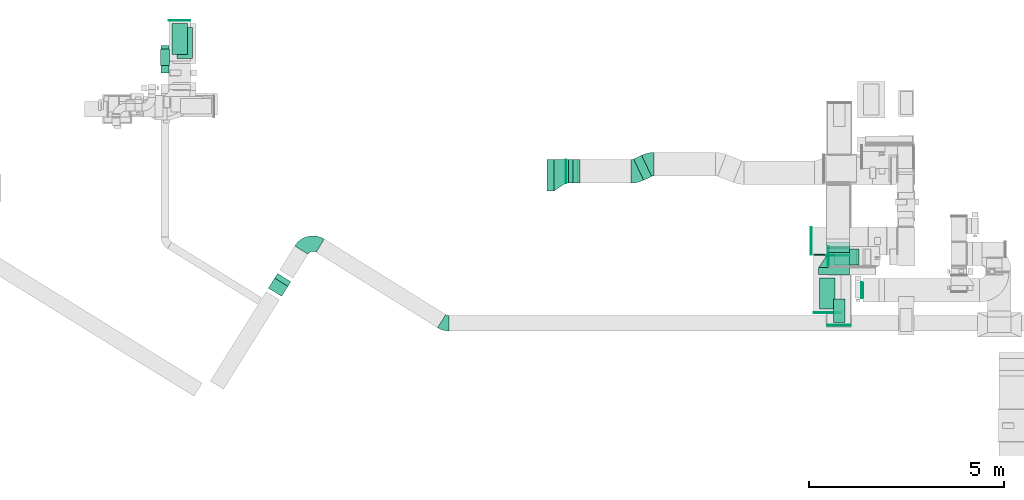
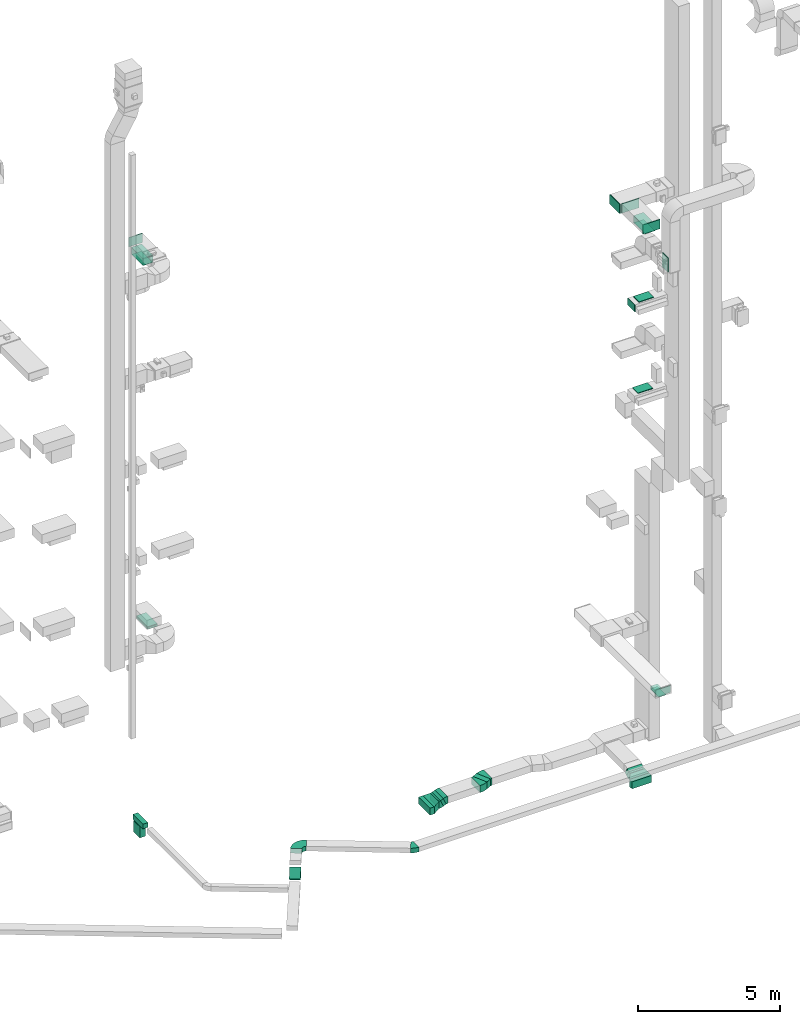
# One storey, part 12 of 29: 20 flow fittings, 17 flow segments, 3 flow terminals.
"""IFC2X3 building model written with IfcOpenShell, lengths in millimetres."""

from ifc_helpers import new_model, entity, si_unit, converted_unit, derived_unit, direction, frame, frame_2d, origin, origin_2d_with_axis, place, context, subcontext, project, spatial, polyline, circle_curve, parameter, trimmed, segment, composite_curve, rectangle, outline, extrude, source, transform, mapped, material, type_object, type_shapes, element, save


model = new_model("IFC2X3")

# Units and contexts
model_context = context("Model", 3, precision=0.01, world=origin(), true_north=direction((6.12303176911189e-17, 1.0)))
body_context = subcontext(model_context, "Body", "Model", "MODEL_VIEW")
ifc_project = project(units=[si_unit("LENGTHUNIT", "METRE", prefix="MILLI"), si_unit("AREAUNIT", "SQUARE_METRE"), si_unit("VOLUMEUNIT", "CUBIC_METRE"), converted_unit("PLANEANGLEUNIT", "DEGREE", entity("IfcRatioMeasure", 0.0174532925199433), si_unit("PLANEANGLEUNIT", "RADIAN"), dimensions=[0, 0, 0, 0, 0, 0, 0]), si_unit("MASSUNIT", "GRAM", prefix="KILO"), derived_unit("MASSDENSITYUNIT", [(si_unit("MASSUNIT", "GRAM", prefix="KILO"), 1), (si_unit("LENGTHUNIT", "METRE"), -3)]), derived_unit("MOMENTOFINERTIAUNIT", [(si_unit("LENGTHUNIT", "METRE"), 4)]), si_unit("TIMEUNIT", "SECOND"), si_unit("FREQUENCYUNIT", "HERTZ"), si_unit("THERMODYNAMICTEMPERATUREUNIT", "DEGREE_CELSIUS"), derived_unit("THERMALTRANSMITTANCEUNIT", [(si_unit("MASSUNIT", "GRAM", prefix="KILO"), 1), (si_unit("THERMODYNAMICTEMPERATUREUNIT", "KELVIN"), -1), (si_unit("TIMEUNIT", "SECOND"), -3)]), derived_unit("VOLUMETRICFLOWRATEUNIT", [(si_unit("LENGTHUNIT", "METRE"), 3), (si_unit("TIMEUNIT", "SECOND"), -1)]), derived_unit("MASSFLOWRATEUNIT", [(si_unit("MASSUNIT", "GRAM", prefix="KILO"), 1), (si_unit("TIMEUNIT", "SECOND"), -1)]), derived_unit("ROTATIONALFREQUENCYUNIT", [(si_unit("TIMEUNIT", "SECOND"), -1)]), si_unit("ELECTRICCURRENTUNIT", "AMPERE"), si_unit("ELECTRICVOLTAGEUNIT", "VOLT"), si_unit("POWERUNIT", "WATT"), si_unit("FORCEUNIT", "NEWTON", prefix="KILO"), si_unit("ILLUMINANCEUNIT", "LUX"), si_unit("LUMINOUSFLUXUNIT", "LUMEN"), si_unit("LUMINOUSINTENSITYUNIT", "CANDELA"), derived_unit("USERDEFINED", [(si_unit("MASSUNIT", "GRAM", prefix="KILO"), -1), (si_unit("LENGTHUNIT", "METRE"), -2), (si_unit("TIMEUNIT", "SECOND"), 3), (si_unit("LUMINOUSFLUXUNIT", "LUMEN"), 1)]), derived_unit("LINEARVELOCITYUNIT", [(si_unit("LENGTHUNIT", "METRE"), 1), (si_unit("TIMEUNIT", "SECOND"), -1)]), si_unit("PRESSUREUNIT", "PASCAL"), derived_unit("USERDEFINED", [(si_unit("LENGTHUNIT", "METRE"), -2), (si_unit("MASSUNIT", "GRAM", prefix="KILO"), 1), (si_unit("TIMEUNIT", "SECOND"), -2)]), derived_unit("LINEARFORCEUNIT", [(si_unit("MASSUNIT", "GRAM", prefix="KILO"), 1), (si_unit("LENGTHUNIT", "METRE"), 1), (si_unit("TIMEUNIT", "SECOND"), -2), (si_unit("LENGTHUNIT", "METRE"), -1)]), derived_unit("PLANARFORCEUNIT", [(si_unit("MASSUNIT", "GRAM", prefix="KILO"), 1), (si_unit("LENGTHUNIT", "METRE"), 1), (si_unit("TIMEUNIT", "SECOND"), -2), (si_unit("LENGTHUNIT", "METRE"), -2)])], contexts=[model_context])

# Site, building, storey
site_placement = place(None, frame((0.0, -0.00077364408347762, 0.0)))
site = spatial("IfcSite", under=ifc_project, at=site_placement, CompositionType="ELEMENT")
building_placement = place(site_placement, origin())
building = spatial("IfcBuilding", under=site, at=building_placement, CompositionType="ELEMENT")
storey_placement = place(building_placement, origin())
storey = spatial("IfcBuildingStorey", under=building, at=storey_placement, CompositionType="ELEMENT", Elevation=0.0)

# Flow segments
duct_segment_type = type_object("IfcDuctSegmentType", PredefinedType="NOTDEFINED")
flow_segment_1_placement = place(storey_placement, frame((28295.0007112237, 9540.31868364391, 22200.0)))
element("IfcFlowSegment", 1, at=flow_segment_1_placement, inside=storey, type_object=duct_segment_type, context=body_context, shape_type="SweptSolid", body=[
    extrude(rectangle(XDim=800.000000000001, YDim=400.0, at=frame_2d((-5.40012479177676e-13, -2.17426077142591e-12), x_axis=(1.0, 0.0))), frame((200.0, 400.0, 0.0), z_axis=(0.0, 0.0, 1.0), x_axis=(0.0, 1.0, 0.0)), (0.0, 0.0, 1.0), 280.000004231565),
])
flow_segment_2_placement = place(storey_placement, frame((28651.0506788633, 9196.30825377642, 2400.0)))
element("IfcFlowSegment", 2, at=flow_segment_2_placement, inside=storey, type_object=duct_segment_type, context=body_context, shape_type="SweptSolid", body=[
    extrude(rectangle(XDim=600.0, YDim=300.000000000001, at=origin_2d_with_axis()), frame((150.0, 300.0, 0.0), z_axis=(0.0, 0.0, 1.0), x_axis=(0.0, 1.0, 0.0)), (0.0, 0.0, 1.0), 79.9999999999699),
])
flow_segment_3_placement = place(storey_placement, frame((11808.2194386705, 15969.9705979415, 7100.0)))
element("IfcFlowSegment", 3, at=flow_segment_3_placement, inside=storey, type_object=duct_segment_type, context=body_context, shape_type="SweptSolid", body=[
    extrude(rectangle(XDim=800.0, YDim=400.0, at=origin_2d_with_axis()), frame((200.0, 400.0, 0.0), z_axis=(0.0, 0.0, 1.0), x_axis=(0.0, 1.0, 0.0)), (0.0, 0.0, 1.0), 79.9999999999991),
])
flow_segment_4_placement = place(storey_placement, frame((11399.830255056, 15599.9756321926, -1100.0)))
element("IfcFlowSegment", 4, at=flow_segment_4_placement, inside=storey, type_object=duct_segment_type, context=body_context, shape_type="SweptSolid", body=[
    extrude(rectangle(XDim=705.699024463295, YDim=200.0, at=frame_2d((0.0, -1.08713038571295e-12), x_axis=(1.0, 0.0))), frame((100.0, 352.849512231647, 0.0), z_axis=(0.0, 0.0, 1.0), x_axis=(0.0, 1.0, 0.0)), (0.0, 0.0, 1.0), 200.0),
])
flow_segment_5_placement = place(storey_placement, frame((11387.330255056, 15795.4315867935, -1600.0)))
element("IfcFlowSegment", 5, at=flow_segment_5_placement, inside=storey, type_object=duct_segment_type, context=body_context, shape_type="SweptSolid", body=[
    extrude(rectangle(XDim=225.000000000001, YDim=425.000000000001, at=frame_2d((0.0, -1.08002495835535e-12), x_axis=(1.0, 0.0))), frame((112.5, 212.500000000012, 0.0), z_axis=(0.0, 0.0, 1.0), x_axis=(-1.0, 0.0, 0.0)), (0.0, 0.0, 1.0), 479.999999999649),
])
flow_segment_6_placement = place(storey_placement, frame((28661.9164691879, 10677.382032688, 14520.0)))
element("IfcFlowSegment", 6, at=flow_segment_6_placement, inside=storey, type_object=duct_segment_type, context=body_context, shape_type="SweptSolid", body=[
    extrude(rectangle(XDim=400.000000000002, YDim=600.000000000002, at=frame_2d((-1.09423581307055e-12, 0.0), x_axis=(1.0, 0.0))), frame((300.0, 200.0, 0.0), z_axis=(0.0, 0.0, 1.0), x_axis=(0.0, 1.0, 0.0)), (0.0, 0.0, 1.0), 30.0000000000387),
])
flow_segment_7_placement = place(storey_placement, frame((14154.2747146984, 9867.26084737813, -997.487373415302)))
element("IfcFlowSegment", 7, at=flow_segment_7_placement, inside=storey, type_object=duct_segment_type, context=body_context, shape_type="SweptSolid", body=[
    extrude(rectangle(XDim=199.999999999998, YDim=400.0, at=frame_2d((6.89226453687297e-13, -9.09494701772928e-13), x_axis=(1.0, 0.0))), frame((207.080569753359, 165.949908803078, 70.7106781186562), z_axis=(0.374709505220615, 0.599660559564594, 0.707106781186548), x_axis=(-0.374709505220592, -0.599660559564608, 0.707106781186548)), (0.0, 0.0, 1.0), 429.289321881347),
])
flow_segment_8_placement = place(storey_placement, frame((28706.9164691876, 10677.3820326881, 18420.0)))
element("IfcFlowSegment", 8, at=flow_segment_8_placement, inside=storey, type_object=duct_segment_type, context=body_context, shape_type="SweptSolid", body=[
    extrude(rectangle(XDim=400.0, YDim=600.000000000002, at=origin_2d_with_axis()), frame((300.0, 200.0, 0.0), z_axis=(0.0, 0.0, 1.0), x_axis=(0.0, 1.0, 0.0)), (0.0, 0.0, 1.0), 30.0000000000148),
])
flow_segment_9_placement = place(storey_placement, frame((29370.5638771014, 9824.92610447663, 20000.0)))
element("IfcFlowSegment", 9, at=flow_segment_9_placement, inside=storey, type_object=duct_segment_type, context=body_context, shape_type="SweptSolid", body=[
    extrude(rectangle(XDim=24.9999999998774, YDim=400.0, at=frame_2d((2.16626716564861e-12, 1.09423581307055e-12), x_axis=(1.0, 0.0))), frame((12.4999999999408, 200.0, 0.0), z_axis=(0.0, 0.0, 1.0), x_axis=(-1.0, 0.0, 0.0)), (0.0, 0.0, 1.0), 600.000000000002),
])
flow_segment_10_placement = place(storey_placement, frame((11675.6422610433, 16071.1270158088, 22700.0)))
element("IfcFlowSegment", 10, at=flow_segment_10_placement, inside=storey, type_object=duct_segment_type, context=body_context, shape_type="SweptSolid", body=[
    extrude(rectangle(XDim=400.0, YDim=800.0, at=origin_2d_with_axis()), frame((200.0, 400.0, 0.0)), (0.0, 0.0, 1.0), 280.00000000001),
])
flow_segment_11_placement = place(storey_placement, frame((21308.4360812954, 12574.7217701702, -2150.0)))
element("IfcFlowSegment", 11, at=flow_segment_11_placement, inside=storey, type_object=duct_segment_type, context=body_context, shape_type="SweptSolid", body=[
    extrude(rectangle(XDim=180.000000000167, YDim=800.0, at=origin_2d_with_axis()), frame((90.0, 400.0, 0.0)), (0.0, 0.0, 1.0), 300.0),
])
flow_segment_12_placement = place(storey_placement, frame((23525.0810005392, 12847.7754426866, -2050.0)))
element("IfcFlowSegment", 12, at=flow_segment_12_placement, inside=storey, type_object=duct_segment_type, context=body_context, shape_type="SweptSolid", body=[
    extrude(rectangle(XDim=226.103922493207, YDim=600.0, at=origin_2d_with_axis()), frame((231.18729973793, 319.446327483498, 0.0), z_axis=(0.0, 0.0, 1.0), x_axis=(0.902595103311304, 0.430490510323348, 0.0)), (0.0, 0.0, 1.0), 300.0),
])
flow_segment_13_placement = place(storey_placement, frame((28269.9546456566, 10424.9994194013, -2150.0)))
element("IfcFlowSegment", 13, at=flow_segment_13_placement, inside=storey, type_object=duct_segment_type, context=body_context, shape_type="SweptSolid", body=[
    extrude(rectangle(XDim=180.000000000057, YDim=800.0, at=frame_2d((-1.08002495835535e-12, 4.34852154285181e-12), x_axis=(1.0, 0.0))), frame((400.0, 90.0, 0.0), z_axis=(0.0, 0.0, 1.0), x_axis=(0.0, -1.0, 0.0)), (0.0, 0.0, 1.0), 300.0),
])
flow_segment_14_placement = place(storey_placement, frame((28469.9546456567, 10904.9994194014, -2150.0)))
element("IfcFlowSegment", 14, at=flow_segment_14_placement, inside=storey, type_object=duct_segment_type, context=body_context, shape_type="SweptSolid", body=[
    extrude(rectangle(XDim=11.7313523662842, YDim=600.000000000002, at=frame_2d((1.0831335828243e-12, 0.0), x_axis=(1.0, 0.0))), frame((300.0, 5.86567618314102, 0.0), z_axis=(0.0, 0.0, 1.0), x_axis=(0.0, 1.0, 0.0)), (0.0, 0.0, 1.0), 300.0),
])
flow_segment_15_placement = place(storey_placement, frame((28469.9546456567, 10991.7307699676, -2089.71143482065)))
element("IfcFlowSegment", 15, at=flow_segment_15_placement, inside=storey, type_object=duct_segment_type, context=body_context, shape_type="SweptSolid", body=[
    extrude(rectangle(XDim=299.999999999998, YDim=139.230496196381, at=frame_2d((9.37916411203332e-13, -5.40012479177676e-13), x_axis=(0.0, 1.0))), frame((0.0, 135.288572026409, 164.711434820695), z_axis=(1.0, 0.0, 0.0), x_axis=(0.0, 0.866025410712421, 0.499999988000383)), (0.0, 0.0, 1.0), 599.999999999998),
])
flow_segment_16_placement = place(storey_placement, frame((21788.4360812956, 12774.7217701701, -2150.0)))
element("IfcFlowSegment", 16, at=flow_segment_16_placement, inside=storey, type_object=duct_segment_type, context=body_context, shape_type="SweptSolid", body=[
    extrude(rectangle(XDim=6.88577027826406, YDim=600.0, at=frame_2d((2.16582307643876e-12, 0.0), x_axis=(1.0, 0.0))), frame((3.44288513912986, 300.0, 0.0)), (0.0, 0.0, 1.0), 300.0),
])
flow_segment_17_placement = place(storey_placement, frame((21855.7610388423, 12774.7217701701, -2111.85427250543)))
element("IfcFlowSegment", 17, at=flow_segment_17_placement, inside=storey, type_object=duct_segment_type, context=body_context, shape_type="SweptSolid", body=[
    extrude(rectangle(XDim=300.000000000003, YDim=121.954891093288, at=frame_2d((5.6843418860808e-14, -1.4210854715202e-13), x_axis=(0.0, 1.0))), frame((116.247679434787, 0.0, 161.854272505441), z_axis=(0.0, 1.0, 0.0), x_axis=(-0.915231716678703, 0.0, -0.402927915122984)), (0.0, 0.0, 1.0), 600.000000000002),
])

# Flow fittings
ifc_material_1 = material()
duct_fitting_type_1 = type_object("IfcDuctFittingType", PredefinedType="NOTDEFINED", material=ifc_material_1)
shared_shape_1 = source(origin(), body_context, "Body", "SweptSolid", [
    extrude(rectangle(XDim=24.9999999999999, YDim=700.0, at=frame_2d((-2.89546164822241e-13, 5.6843418860808e-14), x_axis=(1.0, 0.0))), frame((12.500000000006, 0.0, -200.0)), (0.0, 0.0, 1.0), 400.0),
])
type_shapes(duct_fitting_type_1, [shared_shape_1])
for number, where, z_axis, x_axis in (
    (18, (28495.0007112237, 9460.01414342421, 22500.0), (0.0, 0.0, 1.0), (0.0, -1.0, 0.0)),
    (19, (28095.0012184742, 11289.6152449867, 22500.0), (0.0, 0.0, 1.0), (-1.0, 0.0, 0.0)),
):
    element("IfcFlowFitting", number, at=place(storey_placement, frame(where, z_axis=z_axis, x_axis=x_axis)), inside=storey, type_object=duct_fitting_type_1, material=ifc_material_1, context=body_context, shape_type="MappedRepresentation", body=[
        mapped(shared_shape_1, transform((0.0, 0.0, 0.0), scale=1.0)),
    ])

# Flow terminal
ifc_material_2 = material()
air_terminal_type_1 = type_object("IfcAirTerminalType", PredefinedType="NOTDEFINED", material=ifc_material_2)
shared_shape_2 = source(origin(), body_context, "Body", "SweptSolid", [
    extrude(rectangle(XDim=4.0, YDim=799.999999999999, at=origin_2d_with_axis()), frame((0.0, -2.0, -200.0), z_axis=(0.0, 0.0, 1.0), x_axis=(0.0, 1.0, 0.0)), (0.0, 0.0, 1.0), 400.000000000005),
])
type_shapes(air_terminal_type_1, [shared_shape_2])
flow_terminal_1_placement = place(storey_placement, frame((28495.0007112237, 9940.31868364391, 22200.0), z_axis=(-1.0, 0.0, 0.0), x_axis=(0.0, -1.0, 0.0)))
element("IfcFlowTerminal", 20, at=flow_terminal_1_placement, inside=storey, type_object=air_terminal_type_1, material=ifc_material_2, context=body_context, shape_type="MappedRepresentation", body=[
    mapped(shared_shape_2, transform((0.0, 0.0, 0.0), scale=1.0)),
])

# Flow fittings
duct_fitting_type_2 = type_object("IfcDuctFittingType", PredefinedType="NOTDEFINED", material=ifc_material_1)
shared_shape_3 = source(origin(), body_context, "Body", "SweptSolid", [
    extrude(rectangle(XDim=26.0960000000012, YDim=800.0, at=frame_2d((-6.21724893790088e-13, -5.6843418860808e-14), x_axis=(1.0, 0.0))), frame((6.95199999999999, 0.0, -200.0)), (0.0, 0.0, 1.0), 400.0),
])
type_shapes(duct_fitting_type_2, [shared_shape_3])
flow_fitting_1_placement = place(storey_placement, frame((11875.6422610433, 16471.1270158088, 23000.0), z_axis=(1.0, 0.0, 0.0), x_axis=(0.0, 0.0, -1.0)))
element("IfcFlowFitting", 21, at=flow_fitting_1_placement, inside=storey, type_object=duct_fitting_type_2, material=ifc_material_1, context=body_context, shape_type="MappedRepresentation", body=[
    mapped(shared_shape_3, transform((0.0, 0.0, 0.0), scale=1.0)),
])
duct_fitting_type_3 = type_object("IfcDuctFittingType", PredefinedType="NOTDEFINED", material=ifc_material_1)
shared_shape_4 = source(origin(), body_context, "Body", "SweptSolid", [
    extrude(rectangle(XDim=800.0, YDim=26.096, at=frame_2d((-5.6843418860808e-14, 0.0), x_axis=(1.0, 0.0))), frame((6.95199999999999, 0.0, -200.0), z_axis=(0.0, 0.0, 1.0), x_axis=(0.0, -1.0, 0.0)), (0.0, 0.0, 1.0), 400.0),
])
type_shapes(duct_fitting_type_3, [shared_shape_4])
flow_fitting_2_placement = place(storey_placement, frame((28495.0007112237, 9940.31868364391, 22500.0), z_axis=(-1.0, 0.0, 0.0), x_axis=(0.0, 0.0, -1.0)))
element("IfcFlowFitting", 22, at=flow_fitting_2_placement, inside=storey, type_object=duct_fitting_type_3, material=ifc_material_1, context=body_context, shape_type="MappedRepresentation", body=[
    mapped(shared_shape_4, transform((0.0, 0.0, 0.0), scale=1.0)),
])
duct_fitting_type_4 = type_object("IfcDuctFittingType", PredefinedType="NOTDEFINED", material=ifc_material_1)
shared_shape_5 = source(origin(), body_context, "Body", "SweptSolid", [
    extrude(rectangle(XDim=400.0, YDim=26.0960000000022, at=origin_2d_with_axis()), frame((6.95199999999999, 0.0, -400.0), z_axis=(0.0, 0.0, 1.0), x_axis=(0.0, -1.0, 0.0)), (0.0, 0.0, 1.0), 800.0),
])
type_shapes(duct_fitting_type_4, [shared_shape_5])
flow_fitting_3_placement = place(storey_placement, frame((12008.2194386705, 16369.9705979415, 7200.0), z_axis=(0.0, 1.0, 0.0), x_axis=(0.0, 0.0, -1.0)))
element("IfcFlowFitting", 23, at=flow_fitting_3_placement, inside=storey, type_object=duct_fitting_type_4, material=ifc_material_1, context=body_context, shape_type="MappedRepresentation", body=[
    mapped(shared_shape_5, transform((0.0, 0.0, 0.0), scale=1.0)),
])
duct_fitting_type_5 = type_object("IfcDuctFittingType", PredefinedType="NOTDEFINED", material=ifc_material_1)
shared_shape_6 = source(origin(), body_context, "Body", "SweptSolid", [
    extrude(rectangle(XDim=24.9999999999999, YDim=600.0, at=frame_2d((-2.46913600676635e-13, 0.0), x_axis=(1.0, 0.0))), frame((12.500000000006, 0.0, -150.0)), (0.0, 0.0, 1.0), 300.0),
])
type_shapes(duct_fitting_type_5, [shared_shape_6])
flow_fitting_4_placement = place(storey_placement, frame((28789.0983074609, 9142.07579712693, 2650.0), z_axis=(0.0, 0.0, 1.0), x_axis=(0.0, -1.0, 0.0)))
element("IfcFlowFitting", 24, at=flow_fitting_4_placement, inside=storey, type_object=duct_fitting_type_5, material=ifc_material_1, context=body_context, shape_type="MappedRepresentation", body=[
    mapped(shared_shape_6, transform((0.0, 0.0, 0.0), scale=1.0)),
])
duct_fitting_type_6 = type_object("IfcDuctFittingType", PredefinedType="NOTDEFINED", material=ifc_material_1)
shared_shape_7 = source(origin(), body_context, "Body", "SweptSolid", [
    extrude(rectangle(XDim=300.0, YDim=26.0960000000498, at=frame_2d((-2.8421709430404e-14, 0.0), x_axis=(1.0, 0.0))), frame((6.95200000000595, 0.0, -300.0), z_axis=(0.0, 0.0, 1.0), x_axis=(0.0, -1.0, 0.0)), (0.0, 0.0, 1.0), 600.0),
])
type_shapes(duct_fitting_type_6, [shared_shape_7])
flow_fitting_5_placement = place(storey_placement, frame((28801.0506788633, 9496.30825377643, 2500.0), z_axis=(0.0, 1.0, 0.0), x_axis=(0.0, 0.0, -1.0)))
element("IfcFlowFitting", 25, at=flow_fitting_5_placement, inside=storey, type_object=duct_fitting_type_6, material=ifc_material_1, context=body_context, shape_type="MappedRepresentation", body=[
    mapped(shared_shape_7, transform((0.0, 0.0, 0.0), scale=1.0)),
])

# Flow terminal
air_terminal_type_2 = type_object("IfcAirTerminalType", PredefinedType="NOTDEFINED", material=ifc_material_2)
shared_shape_8 = source(origin(), body_context, "Body", "SweptSolid", [
    extrude(rectangle(XDim=4.0, YDim=599.999999999999, at=origin_2d_with_axis()), frame((0.0, -2.0, -150.0), z_axis=(0.0, 0.0, 1.0), x_axis=(0.0, 1.0, 0.0)), (0.0, 0.0, 1.0), 300.000000000005),
])
type_shapes(air_terminal_type_2, [shared_shape_8])
flow_terminal_2_placement = place(storey_placement, frame((28801.0506788633, 9496.30825377642, 2400.0), z_axis=(-1.0, 0.0, 0.0), x_axis=(0.0, -1.0, 0.0)))
element("IfcFlowTerminal", 26, at=flow_terminal_2_placement, inside=storey, type_object=air_terminal_type_2, material=ifc_material_2, context=body_context, shape_type="MappedRepresentation", body=[
    mapped(shared_shape_8, transform((0.0, 0.0, 0.0), scale=1.0)),
])

# Flow fittings
duct_fitting_type_7 = type_object("IfcDuctFittingType", PredefinedType="NOTDEFINED", material=ifc_material_1)
shared_shape_9 = source(origin(), body_context, "Body", "SweptSolid", [
    extrude(rectangle(XDim=24.9999999999999, YDim=500.0, at=frame_2d((-2.06057393370429e-13, 0.0), x_axis=(1.0, 0.0))), frame((12.5000000000061, 0.0, -150.0)), (0.0, 0.0, 1.0), 300.0),
])
type_shapes(duct_fitting_type_7, [shared_shape_9])
flow_fitting_6_placement = place(storey_placement, frame((28533.9378229566, 10897.3820326881, 18250.0), z_axis=(0.0, 0.0, 1.0), x_axis=(-1.0, 0.0, 0.0)))
element("IfcFlowFitting", 27, at=flow_fitting_6_placement, inside=storey, type_object=duct_fitting_type_7, material=ifc_material_1, context=body_context, shape_type="MappedRepresentation", body=[
    mapped(shared_shape_9, transform((0.0, 0.0, 0.0), scale=1.0)),
])
duct_fitting_type_8 = type_object("IfcDuctFittingType", PredefinedType="NOTDEFINED", material=ifc_material_1)
shared_shape_10 = source(origin(), body_context, "Body", "SweptSolid", [
    extrude(rectangle(XDim=24.9999999999999, YDim=550.0, at=frame_2d((-2.28261853862932e-13, 0.0), x_axis=(1.0, 0.0))), frame((12.500000000006, 0.0, -200.0)), (0.0, 0.0, 1.0), 400.0),
])
type_shapes(duct_fitting_type_8, [shared_shape_10])
flow_fitting_7_placement = place(storey_placement, frame((11874.6422610433, 16933.768186329, 23200.0), z_axis=(0.0, 0.0, 1.0), x_axis=(0.0, 1.0, 0.0)))
element("IfcFlowFitting", 28, at=flow_fitting_7_placement, inside=storey, type_object=duct_fitting_type_8, material=ifc_material_1, context=body_context, shape_type="MappedRepresentation", body=[
    mapped(shared_shape_10, transform((0.0, 0.0, 0.0), scale=1.0)),
])
duct_fitting_type_9 = type_object("IfcDuctFittingType", PredefinedType="NOTDEFINED", material=ifc_material_1)
shared_shape_11 = source(origin(), body_context, "Body", "SweptSolid", [
    extrude(rectangle(XDim=600.0, YDim=26.096, at=origin_2d_with_axis()), frame((6.95199999999999, 0.0, -200.0), z_axis=(0.0, 0.0, 1.0), x_axis=(0.0, -1.0, 0.0)), (0.0, 0.0, 1.0), 400.0),
])
type_shapes(duct_fitting_type_9, [shared_shape_11])
flow_fitting_8_placement = place(storey_placement, frame((29415.5638771012, 10024.9261044766, 20300.0), z_axis=(0.0, 1.0, 0.0), x_axis=(-1.0, 0.0, 0.0)))
element("IfcFlowFitting", 29, at=flow_fitting_8_placement, inside=storey, type_object=duct_fitting_type_9, material=ifc_material_1, context=body_context, shape_type="MappedRepresentation", body=[
    mapped(shared_shape_11, transform((0.0, 0.0, 0.0), scale=1.0)),
])

# Flow terminal
air_terminal_type_3 = type_object("IfcAirTerminalType", PredefinedType="NOTDEFINED", material=ifc_material_2)
shared_shape_12 = source(origin(), body_context, "Body", "SweptSolid", [
    extrude(rectangle(XDim=4.0, YDim=799.999999999999, at=origin_2d_with_axis()), frame((0.0, -2.0, -200.0), z_axis=(0.0, 0.0, 1.0), x_axis=(0.0, 1.0, 0.0)), (0.0, 0.0, 1.0), 400.000000000005),
])
type_shapes(air_terminal_type_3, [shared_shape_12])
flow_terminal_3_placement = place(storey_placement, frame((11875.6422610433, 16470.1270158088, 22700.0), z_axis=(-1.0, 0.0, 0.0), x_axis=(0.0, -1.0, 0.0)))
element("IfcFlowTerminal", 30, at=flow_terminal_3_placement, inside=storey, type_object=air_terminal_type_3, material=ifc_material_2, context=body_context, shape_type="MappedRepresentation", body=[
    mapped(shared_shape_12, transform((0.0, 0.0, 0.0), scale=1.0)),
])

# Flow fittings
duct_fitting_type_10 = type_object("IfcDuctFittingType", PredefinedType="NOTDEFINED", material=ifc_material_1)
shared_shape_13 = source(origin(), body_context, "Body", "SweptSolid", [
    extrude(rectangle(XDim=700.0, YDim=26.096, at=frame_2d((-5.6843418860808e-14, 0.0), x_axis=(1.0, 0.0))), frame((6.95199999999999, 0.0, -200.0), z_axis=(0.0, 0.0, 1.0), x_axis=(0.0, -1.0, 0.0)), (0.0, 0.0, 1.0), 400.0),
])
type_shapes(duct_fitting_type_10, [shared_shape_13])
flow_fitting_9_placement = place(storey_placement, frame((28495.0007112237, 10939.6152449868, 22500.0), z_axis=(0.0, 0.0, -1.0), x_axis=(0.0, -1.0, 0.0)))
element("IfcFlowFitting", 31, at=flow_fitting_9_placement, inside=storey, type_object=duct_fitting_type_10, material=ifc_material_1, context=body_context, shape_type="MappedRepresentation", body=[
    mapped(shared_shape_13, transform((0.0, 0.0, 0.0), scale=1.0)),
])
duct_fitting_type_11 = type_object("IfcDuctFittingType", PredefinedType="NOTDEFINED", material=ifc_material_1)
shared_shape_14 = source(origin(), body_context, "Body", "SweptSolid", [
    extrude(outline(composite_curve([segment(polyline([(-321.916101754957, -96.8603648227543), (278.083898245043, -96.8603648227543)]), True, "CONTINUOUS"), segment(trimmed(circle_curve(frame_2d((428.083898245043, -96.8603648227542), x_axis=(-0.902595103311302, 0.430490510323354)), 150.0), [parameter(0.0)], [parameter(25.4986931846699)], True, "PARAMETER"), False, "CONTINUOUS"), segment(polyline([(292.694632748348, -32.2867882742513), (-248.862429238433, 226.007517919761)]), True, "CONTINUOUS"), segment(trimmed(circle_curve(frame_2d((428.083898245043, -96.8603648227542), x_axis=(-0.902595103311302, 0.430490510323354)), 750.0), [parameter(0.0)], [parameter(25.4986931846699)], True, "PARAMETER"), True, "CONTINUOUS")], self_intersect=False)), frame((-4.95884479696041, 21.9161017549489, -150.0), z_axis=(0.0, 0.0, 1.0), x_axis=(-0.430490510323354, 0.902595103311301, 0.0)), (0.0, 0.0, 1.0), 300.0),
])
type_shapes(duct_fitting_type_11, [shared_shape_14])
flow_fitting_10_placement = place(storey_placement, frame((23950.2099669438, 13259.7217701701, -1900.0), z_axis=(0.0, 0.0, 1.0), x_axis=(-1.0, 0.0, 0.0)))
element("IfcFlowFitting", 32, at=flow_fitting_10_placement, inside=storey, type_object=duct_fitting_type_11, material=ifc_material_1, context=body_context, shape_type="MappedRepresentation", body=[
    mapped(shared_shape_14, transform((0.0, 0.0, 0.0), scale=1.0)),
])
flow_fitting_11_placement = place(storey_placement, frame((23562.3266336104, 13074.7217701701, -1900.0)))
element("IfcFlowFitting", 33, at=flow_fitting_11_placement, inside=storey, type_object=duct_fitting_type_11, material=ifc_material_1, context=body_context, shape_type="MappedRepresentation", body=[
    mapped(shared_shape_14, transform((0.0, 0.0, 0.0), scale=1.0)),
])
duct_fitting_type_12 = type_object("IfcDuctFittingType", PredefinedType="NOTDEFINED", material=ifc_material_1)
shared_shape_15 = source(origin(), body_context, "Body", "SweptSolid", [
    extrude(outline(polyline([(-374.42263245203, -291.217603018245), (-13.867504905631, -291.217603018245), (318.952612829507, 208.012573584461), (69.337524528154, 374.422632452029), (-374.42263245203, -291.217603018245)])), frame((150.0, 50.0, -150.0), z_axis=(0.0, 0.0, 1.0), x_axis=(0.832050294337843, 0.55470019622523, 0.0)), (0.0, 0.0, 1.0), 300.0),
])
type_shapes(duct_fitting_type_12, [shared_shape_15])
flow_fitting_12_placement = place(storey_placement, frame((21488.4360812955, 12974.7217701702, -2000.0)))
element("IfcFlowFitting", 34, at=flow_fitting_12_placement, inside=storey, type_object=duct_fitting_type_12, material=ifc_material_1, context=body_context, shape_type="MappedRepresentation", body=[
    mapped(shared_shape_15, transform((0.0, 0.0, 0.0), scale=1.0)),
])
duct_fitting_type_13 = type_object("IfcDuctFittingType", PredefinedType="NOTDEFINED", material=ifc_material_1)
shared_shape_16 = source(origin(), body_context, "Body", "SweptSolid", [
    extrude(outline(polyline([(-150.0, -350.0), (150.0, -350.0), (150.0, 250.0), (-150.0, 450.0), (-150.0, -350.0)])), frame((150.0, -50.0, -150.0)), (0.0, 0.0, 1.0), 300.0),
])
type_shapes(duct_fitting_type_13, [shared_shape_16])
flow_fitting_13_placement = place(storey_placement, frame((28669.9546456566, 10604.9994194013, -2000.0), z_axis=(0.0, 0.0, 1.0), x_axis=(0.0, 1.0, 0.0)))
element("IfcFlowFitting", 35, at=flow_fitting_13_placement, inside=storey, type_object=duct_fitting_type_13, material=ifc_material_1, context=body_context, shape_type="MappedRepresentation", body=[
    mapped(shared_shape_16, transform((0.0, 0.0, 0.0), scale=1.0)),
])
duct_fitting_type_14 = type_object("IfcDuctFittingType", PredefinedType="NOTDEFINED", material=ifc_material_1)
shared_shape_17 = source(origin(), body_context, "Body", "SweptSolid", [
    extrude(outline(composite_curve([segment(polyline([(-170.096188393128, -74.9999982000424), (129.903811606872, -74.9999982000425)]), True, "CONTINUOUS"), segment(trimmed(circle_curve(frame_2d((279.903811606872, -74.9999982000425), x_axis=(-0.866025410712478, 0.499999988000285)), 150.0), [parameter(0.0)], [parameter(29.9999992061053)], True, "PARAMETER"), False, "CONTINUOUS"), segment(polyline([(150.0, 0.0), (-109.807623213743, 149.999996400086)]), True, "CONTINUOUS"), segment(trimmed(circle_curve(frame_2d((279.903811606872, -74.9999982000425), x_axis=(-0.866025410712478, 0.499999988000285)), 450.0), [parameter(0.0)], [parameter(29.9999992061053)], True, "PARAMETER"), True, "CONTINUOUS")], self_intersect=False)), frame((-5.38475730165266, 20.09618839312, -300.0), z_axis=(0.0, 0.0, 1.0), x_axis=(-0.499999988000285, 0.866025410712477, 0.0)), (0.0, 0.0, 1.0), 600.0),
])
type_shapes(duct_fitting_type_14, [shared_shape_17])
flow_fitting_14_placement = place(storey_placement, frame((28769.9546456567, 10997.1155272694, -2000.0), z_axis=(1.0, 0.0, 0.0), x_axis=(0.0, 1.0, 0.0)))
element("IfcFlowFitting", 36, at=flow_fitting_14_placement, inside=storey, type_object=duct_fitting_type_14, material=ifc_material_1, context=body_context, shape_type="MappedRepresentation", body=[
    mapped(shared_shape_17, transform((0.0, 0.0, 0.0), scale=1.0)),
])
duct_fitting_type_15 = type_object("IfcDuctFittingType", PredefinedType="NOTDEFINED", material=ifc_material_1)
shared_shape_18 = source(origin(), body_context, "Body", "SweptSolid", [
    extrude(outline(composite_curve([segment(polyline([(-162.715242498186, -60.4391872684276), (137.284757501814, -60.4391872684277)]), True, "CONTINUOUS"), segment(trimmed(circle_curve(frame_2d((287.284757501814, -60.4391872684277), x_axis=(-0.915231716678761, 0.402927915122853)), 150.0), [parameter(0.0)], [parameter(23.7613446574382)], True, "PARAMETER"), False, "CONTINUOUS"), segment(polyline([(150.0, 0.0), (-124.569515003628, 120.878374536856)]), True, "CONTINUOUS"), segment(trimmed(circle_curve(frame_2d((287.284757501814, -60.4391872684277), x_axis=(-0.915231716678761, 0.402927915122853)), 450.0), [parameter(0.0)], [parameter(23.7613446574382)], True, "PARAMETER"), True, "CONTINUOUS")], self_intersect=False)), frame((-2.67504245332123, 12.7152424981775, -300.0), z_axis=(0.0, 0.0, 1.0), x_axis=(-0.402927915122853, 0.915231716678761, 0.0)), (0.0, 0.0, 1.0), 600.0),
])
type_shapes(duct_fitting_type_15, [shared_shape_18])
for number, where, z_axis, x_axis in (
    (37, (22085.5813552585, 13074.7217701701, -1900.0), (0.0, -1.0, 0.0), (-1.0, 0.0, 0.0)),
    (38, (21858.4360812956, 13074.7217701701, -2000.0), (0.0, -1.0, 0.0), (1.0, 0.0, 0.0)),
):
    element("IfcFlowFitting", number, at=place(storey_placement, frame(where, z_axis=z_axis, x_axis=x_axis)), inside=storey, type_object=duct_fitting_type_15, material=ifc_material_1, context=body_context, shape_type="MappedRepresentation", body=[
        mapped(shared_shape_18, transform((0.0, 0.0, 0.0), scale=1.0)),
    ])
duct_fitting_type_16 = type_object("IfcDuctFittingType", PredefinedType="NOTDEFINED", material=ifc_material_1)
shared_shape_19 = source(origin(), body_context, "Body", "SweptSolid", [
    extrude(outline(composite_curve([segment(polyline([(-226.332871259837, -92.3205547652074), (173.667128740163, -92.3205547652076)]), True, "CONTINUOUS"), segment(trimmed(circle_curve(frame_2d((323.667128740163, -92.3205547652076), x_axis=(-0.849526449943788, 0.527546027229758)), 150.0), [parameter(0.0)], [parameter(31.8397992290732)], True, "PARAMETER"), False, "CONTINUOUS"), segment(polyline([(196.238161248595, -13.1886506807438), (-143.572418728921, 197.82976021116)]), True, "CONTINUOUS"), segment(trimmed(circle_curve(frame_2d((323.667128740163, -92.3205547652076), x_axis=(-0.849526449943788, 0.527546027229758)), 550.0), [parameter(0.0)], [parameter(31.8397992290732)], True, "PARAMETER"), True, "CONTINUOUS")], self_intersect=False)), frame((-7.51100457043461, 26.3328712598284, -100.0), z_axis=(0.0, 0.0, 1.0), x_axis=(-0.527546027229759, 0.84952644994379, 0.0)), (0.0, 0.0, 1.0), 200.0),
])
type_shapes(duct_fitting_type_16, [shared_shape_19])
flow_fitting_15_placement = place(storey_placement, frame((18683.4440697656, 9180.00003916106, -550.0), z_axis=(0.0, 0.0, 1.0), x_axis=(0.84952644994379, -0.527546027229759, 0.0)))
element("IfcFlowFitting", 39, at=flow_fitting_15_placement, inside=storey, type_object=duct_fitting_type_16, material=ifc_material_1, context=body_context, shape_type="MappedRepresentation", body=[
    mapped(shared_shape_19, transform((0.0, 0.0, 0.0), scale=1.0)),
])
duct_fitting_type_17 = type_object("IfcDuctFittingType", PredefinedType="NOTDEFINED", material=ifc_material_1)
shared_shape_20 = source(origin(), body_context, "Body", "SweptSolid", [
    extrude(outline(composite_curve([segment(polyline([(-374.510695227089, -174.999315943918), (25.489304772911, -174.999315943918)]), True, "CONTINUOUS"), segment(trimmed(circle_curve(frame_2d((175.489304772911, -174.999315943918), x_axis=(-0.00279602727377437, 0.999996091108102)), 150.0), [parameter(0.0)], [parameter(89.8397992290734)], True, "PARAMETER"), False, "CONTINUOUS"), segment(polyline([(175.069900681844, -24.9999022777024), (173.951489772334, 374.998534165539)]), True, "CONTINUOUS"), segment(trimmed(circle_curve(frame_2d((175.489304772911, -174.999315943918), x_axis=(-0.00279602727377437, 0.999996091108102)), 550.0), [parameter(0.0)], [parameter(89.8397992290733)], True, "PARAMETER"), True, "CONTINUOUS")], self_intersect=False)), frame((-174.023438802472, 174.510695227081, -100.0), z_axis=(0.0, 0.0, 1.0), x_axis=(-0.999996091108103, 0.00279602727377631, 0.0)), (0.0, 0.0, 1.0), 200.0),
])
type_shapes(duct_fitting_type_17, [shared_shape_20])
flow_fitting_16_placement = place(storey_placement, frame((15185.5290586659, 11352.1645053941, -550.0), z_axis=(0.0, 0.0, 1.0), x_axis=(-0.849526449943789, 0.527546027229761, 0.0)))
element("IfcFlowFitting", 40, at=flow_fitting_16_placement, inside=storey, type_object=duct_fitting_type_17, material=ifc_material_1, context=body_context, shape_type="MappedRepresentation", body=[
    mapped(shared_shape_20, transform((0.0, 0.0, 0.0), scale=1.0)),
])

save(model, "model.ifc")
